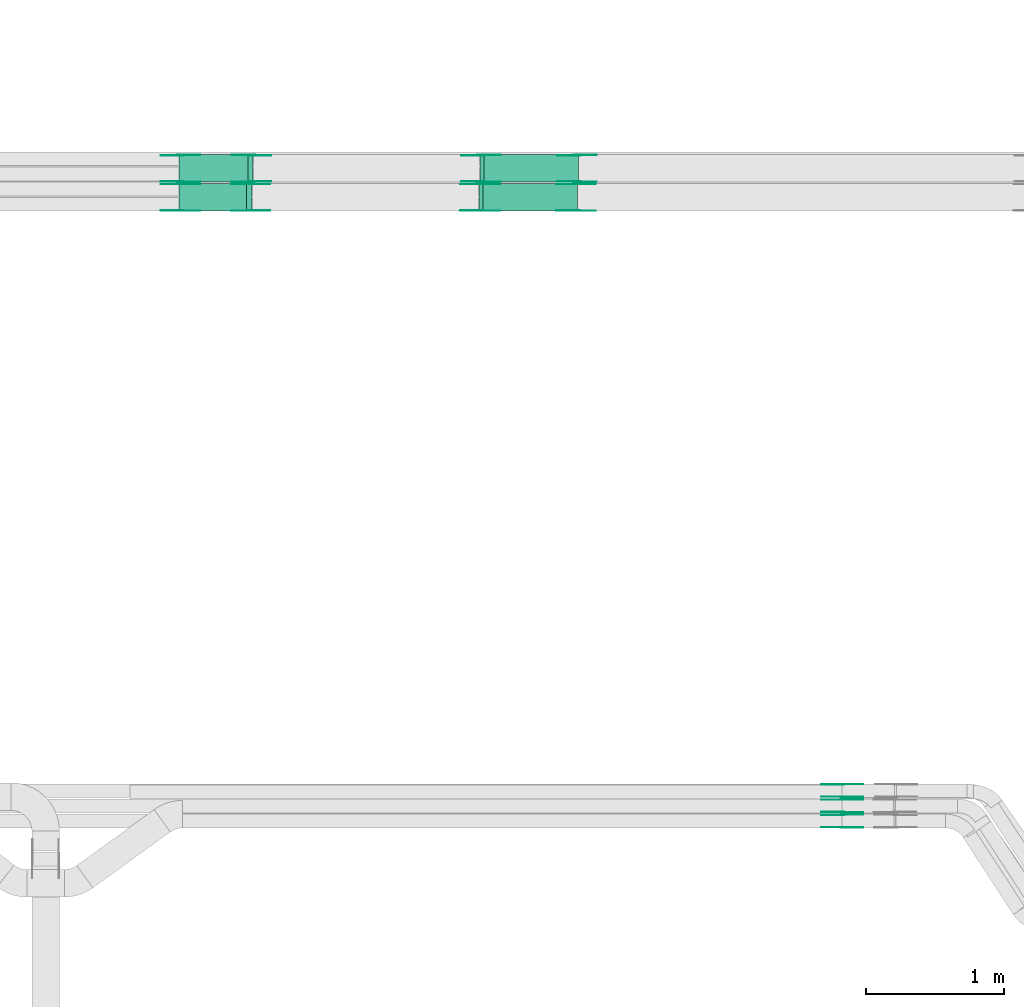
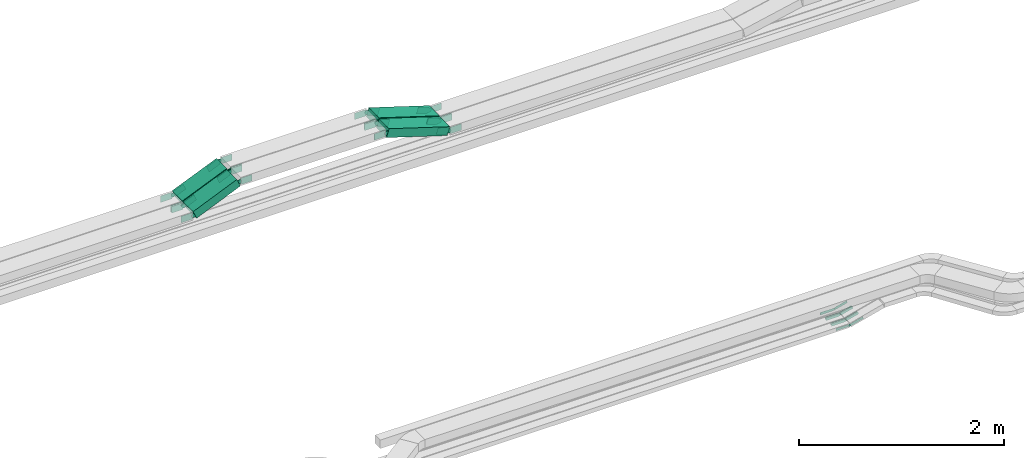
# One storey, part 6 of 25: 44 flow fittings, 4 flow segments.
"""IFC2X3 building model written with IfcOpenShell, lengths in millimetres."""

from ifc_helpers import new_model, entity, si_unit, converted_unit, derived_unit, direction, frame, frame_2d, origin, place, context, subcontext, project, spatial, polyline, circle_curve, parameter, trimmed, segment, composite_curve, rectangle, outline, extrude, source, transform, mapped, material, type_object, type_shapes, element, save


model = new_model("IFC2X3")

# Units and contexts
model_context = context("Model", 3, precision=0.01, world=origin(), true_north=direction((6.12303176911189e-17, 1.0)))
body_context = subcontext(model_context, "Body", "Model", "MODEL_VIEW")
ifc_project = project(units=[si_unit("LENGTHUNIT", "METRE", prefix="MILLI"), si_unit("AREAUNIT", "SQUARE_METRE"), si_unit("VOLUMEUNIT", "CUBIC_METRE"), converted_unit("PLANEANGLEUNIT", "DEGREE", entity("IfcRatioMeasure", 0.0174532925199433), si_unit("PLANEANGLEUNIT", "RADIAN"), dimensions=[0, 0, 0, 0, 0, 0, 0]), si_unit("MASSUNIT", "GRAM", prefix="KILO"), derived_unit("MASSDENSITYUNIT", [(si_unit("MASSUNIT", "GRAM", prefix="KILO"), 1), (si_unit("LENGTHUNIT", "METRE"), -3)]), derived_unit("MOMENTOFINERTIAUNIT", [(si_unit("LENGTHUNIT", "METRE"), 4)]), si_unit("TIMEUNIT", "SECOND"), si_unit("FREQUENCYUNIT", "HERTZ"), si_unit("THERMODYNAMICTEMPERATUREUNIT", "DEGREE_CELSIUS"), derived_unit("THERMALTRANSMITTANCEUNIT", [(si_unit("MASSUNIT", "GRAM", prefix="KILO"), 1), (si_unit("THERMODYNAMICTEMPERATUREUNIT", "KELVIN"), -1), (si_unit("TIMEUNIT", "SECOND"), -3)]), derived_unit("VOLUMETRICFLOWRATEUNIT", [(si_unit("LENGTHUNIT", "METRE"), 3), (si_unit("TIMEUNIT", "SECOND"), -1)]), derived_unit("MASSFLOWRATEUNIT", [(si_unit("MASSUNIT", "GRAM", prefix="KILO"), 1), (si_unit("TIMEUNIT", "SECOND"), -1)]), derived_unit("ROTATIONALFREQUENCYUNIT", [(si_unit("TIMEUNIT", "SECOND"), -1)]), si_unit("ELECTRICCURRENTUNIT", "AMPERE"), si_unit("ELECTRICVOLTAGEUNIT", "VOLT"), si_unit("POWERUNIT", "WATT"), si_unit("FORCEUNIT", "NEWTON", prefix="KILO"), si_unit("ILLUMINANCEUNIT", "LUX"), si_unit("LUMINOUSFLUXUNIT", "LUMEN"), si_unit("LUMINOUSINTENSITYUNIT", "CANDELA"), derived_unit("USERDEFINED", [(si_unit("MASSUNIT", "GRAM", prefix="KILO"), -1), (si_unit("LENGTHUNIT", "METRE"), -2), (si_unit("TIMEUNIT", "SECOND"), 3), (si_unit("LUMINOUSFLUXUNIT", "LUMEN"), 1)]), derived_unit("LINEARVELOCITYUNIT", [(si_unit("LENGTHUNIT", "METRE"), 1), (si_unit("TIMEUNIT", "SECOND"), -1)]), si_unit("PRESSUREUNIT", "PASCAL"), derived_unit("USERDEFINED", [(si_unit("LENGTHUNIT", "METRE"), -2), (si_unit("MASSUNIT", "GRAM", prefix="KILO"), 1), (si_unit("TIMEUNIT", "SECOND"), -2)]), derived_unit("LINEARFORCEUNIT", [(si_unit("MASSUNIT", "GRAM", prefix="KILO"), 1), (si_unit("LENGTHUNIT", "METRE"), 1), (si_unit("TIMEUNIT", "SECOND"), -2), (si_unit("LENGTHUNIT", "METRE"), -1)]), derived_unit("PLANARFORCEUNIT", [(si_unit("MASSUNIT", "GRAM", prefix="KILO"), 1), (si_unit("LENGTHUNIT", "METRE"), 1), (si_unit("TIMEUNIT", "SECOND"), -2), (si_unit("LENGTHUNIT", "METRE"), -2)])], contexts=[model_context])

# Site, building, storey
site_placement = place(None, frame((0.0, -0.00077364408347762, 0.0)))
site = spatial("IfcSite", under=ifc_project, at=site_placement, CompositionType="ELEMENT")
building_placement = place(site_placement, origin())
building = spatial("IfcBuilding", under=site, at=building_placement, CompositionType="ELEMENT")
storey_placement = place(building_placement, frame((0.0, 0.0, 24000.0)))
storey = spatial("IfcBuildingStorey", under=building, at=storey_placement, CompositionType="ELEMENT", Elevation=24000.0)

# Flow segments
cable_carrier_segment_type = type_object("IfcCableCarrierSegmentType", PredefinedType="CABLETRAYSEGMENT")
flow_segment_1_placement = place(storey_placement, frame((23750.3450930717, 14577.8235638228, 2908.57283587758)))
element("IfcFlowSegment", 1, at=flow_segment_1_placement, inside=storey, type_object=cable_carrier_segment_type, context=body_context, shape_type="SweptSolid", body=[
    extrude(rectangle(XDim=99.9999999999979, YDim=200.000000000002, at=frame_2d((-1.99307237380708e-12, 0.0), x_axis=(1.0, 0.0))), frame((19.4417182178709, 100.0, 46.0653838878744), z_axis=(0.921307677757376, 0.0, 0.388834364357512), x_axis=(-0.388834364357512, 0.0, 0.921307677757376)), (0.0, 0.0, 1.0), 541.93656678797),
])
flow_segment_2_placement = place(storey_placement, frame((25932.6643510058, 14577.8235638228, 2905.08448003901)))
element("IfcFlowSegment", 2, at=flow_segment_2_placement, inside=storey, type_object=cable_carrier_segment_type, context=body_context, shape_type="SweptSolid", body=[
    extrude(rectangle(XDim=99.9999999999984, YDim=200.000000000002, at=frame_2d((-4.13180600844498e-12, -2.16715534406831e-12), x_axis=(1.0, 0.0))), frame((14.9913298370202, 100.0, 262.131354076939), z_axis=(0.953993716901251, 0.0, -0.299826596740408), x_axis=(0.299826596740408, 0.0, 0.953993716901251)), (0.0, 0.0, 1.0), 715.185612494235),
])
flow_segment_3_placement = place(storey_placement, frame((23750.2231629393, 14367.8235638228, 2908.77709176211)))
element("IfcFlowSegment", 3, at=flow_segment_3_placement, inside=storey, type_object=cable_carrier_segment_type, context=body_context, shape_type="SweptSolid", body=[
    extrude(rectangle(XDim=99.9999999999976, YDim=200.000000000002, at=frame_2d((1.99307237380708e-12, -2.16715534406831e-12), x_axis=(1.0, 0.0))), frame((19.6676952250639, 100.0, 45.9693567992209), z_axis=(0.919387135984397, 0.0, 0.393353904501287), x_axis=(-0.393353904501287, 0.0, 0.919387135984397)), (0.0, 0.0, 1.0), 535.159561068118),
])
flow_segment_4_placement = place(storey_placement, frame((25925.6009410613, 14367.8235638228, 2905.08448003901)))
element("IfcFlowSegment", 4, at=flow_segment_4_placement, inside=storey, type_object=cable_carrier_segment_type, context=body_context, shape_type="SweptSolid", body=[
    extrude(rectangle(XDim=99.9999999999984, YDim=200.000000000002, at=frame_2d((-4.13180600844498e-12, -2.16715534406831e-12), x_axis=(1.0, 0.0))), frame((14.9913298370202, 100.0, 262.131354076939), z_axis=(0.953993716901251, 0.0, -0.299826596740408), x_axis=(0.299826596740408, 0.0, 0.953993716901251)), (0.0, 0.0, 1.0), 715.185612494268),
])

# Flow fittings
ifc_material = material(Name="G")
cable_carrier_fitting_type_1 = type_object("IfcCableCarrierFittingType", PredefinedType="NOTDEFINED", material=ifc_material)
shared_shape_1 = source(origin(), body_context, "Body", "SweptSolid", [
    extrude(outline(composite_curve([segment(trimmed(circle_curve(frame_2d((-44.5901162790698, 0.0), x_axis=(1.0, 0.0)), 12.5), [parameter(90.0000000000007)], [parameter(270.0)], True, "PARAMETER"), True, "CONTINUOUS"), segment(polyline([(-44.5901162790697, -12.5), (-33.0901162790698, -12.5)]), True, "CONTINUOUS"), segment(polyline([(-33.0901162790698, -12.5), (-31.2296511627907, -14.5)]), True, "CONTINUOUS"), segment(polyline([(-31.2296511627907, -14.5), (108.90988372093, -14.5)]), True, "CONTINUOUS"), segment(polyline([(108.90988372093, -14.5), (108.90988372093, 14.5)]), True, "CONTINUOUS"), segment(polyline([(108.90988372093, 14.5), (-31.2296511627907, 14.5)]), True, "CONTINUOUS"), segment(polyline([(-31.2296511627907, 14.5), (-33.0901162790698, 12.5)]), True, "CONTINUOUS"), segment(polyline([(-33.0901162790698, 12.5), (-44.5901162790699, 12.5)]), True, "CONTINUOUS")], self_intersect=False)), frame((44.5901162790698, 0.0, 0.0), z_axis=(0.0, 0.0, -1.0), x_axis=(1.0, 0.0, 0.0)), (0.0, 0.0, -1.0), 2.0),
])
type_shapes(cable_carrier_fitting_type_1, [shared_shape_1])
for number, where, z_axis, x_axis in (
    (5, (28559.4016711443, 9902.36356392034, 2675.0), (0.0, -1.0, 0.0), (0.967755764973795, 0.0, 0.251890411409375)),
    (6, (28559.4017850089, 10012.3635639189, 2675.00051930279), (0.0, -1.0, 0.0), (0.96722840614087, 0.0, 0.253907877692269)),
    (7, (28559.4017847479, 10122.3635639181, 2675.00051541508), (0.0, -1.0, 0.0), (0.968482292862195, 0.0, 0.249082412892571)),
):
    element("IfcFlowFitting", number, at=place(storey_placement, frame(where, z_axis=z_axis, x_axis=x_axis)), inside=storey, type_object=cable_carrier_fitting_type_1, material=ifc_material, context=body_context, shape_type="MappedRepresentation", body=[
        mapped(shared_shape_1, transform((0.0, 0.0, 0.0), scale=1.0)),
    ])
cable_carrier_fitting_type_2 = type_object("IfcCableCarrierFittingType", PredefinedType="NOTDEFINED", material=ifc_material)
shared_shape_2 = source(origin(), body_context, "Body", "SweptSolid", [
    extrude(outline(composite_curve([segment(trimmed(circle_curve(frame_2d((-44.5901162790697, 0.0), x_axis=(1.0, 0.0)), 12.5), [parameter(90.0000000000007)], [parameter(270.0)], True, "PARAMETER"), True, "CONTINUOUS"), segment(polyline([(-44.5901162790697, -12.5), (-33.0901162790697, -12.5)]), True, "CONTINUOUS"), segment(polyline([(-33.0901162790697, -12.5), (-31.2296511627907, -14.5)]), True, "CONTINUOUS"), segment(polyline([(-31.2296511627907, -14.5), (108.90988372093, -14.5)]), True, "CONTINUOUS"), segment(polyline([(108.90988372093, -14.5), (108.90988372093, 14.5)]), True, "CONTINUOUS"), segment(polyline([(108.90988372093, 14.5), (-31.2296511627907, 14.5)]), True, "CONTINUOUS"), segment(polyline([(-31.2296511627907, 14.5), (-33.0901162790698, 12.5)]), True, "CONTINUOUS"), segment(polyline([(-33.0901162790698, 12.5), (-44.5901162790699, 12.5)]), True, "CONTINUOUS")], self_intersect=False)), frame((44.5901162790697, 0.0, 0.0)), (0.0, 0.0, 1.0), 2.0),
])
type_shapes(cable_carrier_fitting_type_2, [shared_shape_2])
for number, where, z_axis, x_axis in (
    (8, (28559.4016711443, 9993.28356394066, 2675.0), (0.0, 1.0, 0.0), (0.967755764973795, 0.0, 0.251890411409375)),
    (9, (28559.4017850089, 10103.2835639393, 2675.00051930279), (0.0, 1.0, 0.0), (0.96722840614087, 0.0, 0.253907877692269)),
    (10, (28559.4017847479, 10213.2835639385, 2675.00051541508), (0.0, 1.0, 0.0), (0.968482292862195, 0.0, 0.249082412892571)),
):
    element("IfcFlowFitting", number, at=place(storey_placement, frame(where, z_axis=z_axis, x_axis=x_axis)), inside=storey, type_object=cable_carrier_fitting_type_2, material=ifc_material, context=body_context, shape_type="MappedRepresentation", body=[
        mapped(shared_shape_2, transform((0.0, 0.0, 0.0), scale=1.0)),
    ])
cable_carrier_fitting_type_3 = type_object("IfcCableCarrierFittingType", PredefinedType="NOTDEFINED", material=ifc_material)
shared_shape_3 = source(origin(), body_context, "Body", "SweptSolid", [
    extrude(outline(composite_curve([segment(trimmed(circle_curve(frame_2d((-44.5901162790698, 0.0), x_axis=(1.0, 0.0)), 12.5), [parameter(90.0000000000007)], [parameter(270.0)], True, "PARAMETER"), True, "CONTINUOUS"), segment(polyline([(-44.5901162790697, -12.5), (-33.0901162790698, -12.5)]), True, "CONTINUOUS"), segment(polyline([(-33.0901162790698, -12.5), (-31.2296511627907, -14.5)]), True, "CONTINUOUS"), segment(polyline([(-31.2296511627907, -14.5), (108.90988372093, -14.5)]), True, "CONTINUOUS"), segment(polyline([(108.90988372093, -14.5), (108.90988372093, 14.5)]), True, "CONTINUOUS"), segment(polyline([(108.90988372093, 14.5), (-31.2296511627907, 14.5)]), True, "CONTINUOUS"), segment(polyline([(-31.2296511627907, 14.5), (-33.0901162790698, 12.5)]), True, "CONTINUOUS"), segment(polyline([(-33.0901162790698, 12.5), (-44.5901162790699, 12.5)]), True, "CONTINUOUS")], self_intersect=False)), frame((44.5901162790698, 0.0, 0.0), z_axis=(0.0, 0.0, -1.0), x_axis=(1.0, 0.0, 0.0)), (0.0, 0.0, -1.0), 2.0),
])
type_shapes(cable_carrier_fitting_type_3, [shared_shape_3])
for number, where, z_axis, x_axis in (
    (11, (28559.4016711443, 9991.28356394066, 2675.0), (0.0, 1.0, 0.0), (-1.0, 0.0, 0.0)),
    (12, (28559.4017850089, 10101.2835639393, 2675.0005193028), (0.0, 1.0, 0.0), (-1.0, 0.0, -5.74450066331542e-08)),
    (13, (28559.4017847479, 10211.2835639385, 2675.00051541509), (0.0, 1.0, 0.0), (-1.0, 0.0, -5.70149502338435e-08)),
):
    element("IfcFlowFitting", number, at=place(storey_placement, frame(where, z_axis=z_axis, x_axis=x_axis)), inside=storey, type_object=cable_carrier_fitting_type_3, material=ifc_material, context=body_context, shape_type="MappedRepresentation", body=[
        mapped(shared_shape_3, transform((0.0, 0.0, 0.0), scale=1.0)),
    ])
cable_carrier_fitting_type_4 = type_object("IfcCableCarrierFittingType", PredefinedType="NOTDEFINED", material=ifc_material)
shared_shape_4 = source(origin(), body_context, "Body", "SweptSolid", [
    extrude(outline(composite_curve([segment(trimmed(circle_curve(frame_2d((-44.5901162790697, 0.0), x_axis=(1.0, 0.0)), 12.5), [parameter(90.0000000000007)], [parameter(270.0)], True, "PARAMETER"), True, "CONTINUOUS"), segment(polyline([(-44.5901162790697, -12.5), (-33.0901162790697, -12.5)]), True, "CONTINUOUS"), segment(polyline([(-33.0901162790697, -12.5), (-31.2296511627907, -14.5)]), True, "CONTINUOUS"), segment(polyline([(-31.2296511627907, -14.5), (108.90988372093, -14.5)]), True, "CONTINUOUS"), segment(polyline([(108.90988372093, -14.5), (108.90988372093, 14.5)]), True, "CONTINUOUS"), segment(polyline([(108.90988372093, 14.5), (-31.2296511627907, 14.5)]), True, "CONTINUOUS"), segment(polyline([(-31.2296511627907, 14.5), (-33.0901162790698, 12.5)]), True, "CONTINUOUS"), segment(polyline([(-33.0901162790698, 12.5), (-44.5901162790699, 12.5)]), True, "CONTINUOUS")], self_intersect=False)), frame((44.5901162790697, 0.0, 0.0)), (0.0, 0.0, 1.0), 2.0),
])
type_shapes(cable_carrier_fitting_type_4, [shared_shape_4])
for number, where, z_axis, x_axis in (
    (14, (28559.4016711443, 9904.36356392034, 2675.0), (0.0, -1.0, 0.0), (-1.0, 0.0, 0.0)),
    (15, (28559.4017850089, 10014.3635639189, 2675.0005193028), (0.0, -1.0, 0.0), (-1.0, 0.0, -5.74450066331542e-08)),
    (16, (28559.4017847479, 10124.3635639181, 2675.00051541509), (0.0, -1.0, 0.0), (-1.0, 0.0, -5.70149502338435e-08)),
):
    element("IfcFlowFitting", number, at=place(storey_placement, frame(where, z_axis=z_axis, x_axis=x_axis)), inside=storey, type_object=cable_carrier_fitting_type_4, material=ifc_material, context=body_context, shape_type="MappedRepresentation", body=[
        mapped(shared_shape_4, transform((0.0, 0.0, 0.0), scale=1.0)),
    ])
cable_carrier_fitting_type_5 = type_object("IfcCableCarrierFittingType", PredefinedType="NOTDEFINED", material=ifc_material)
shared_shape_5 = source(origin(), body_context, "Body", "SweptSolid", [
    extrude(outline(composite_curve([segment(trimmed(circle_curve(frame_2d((-41.4651162790697, 0.0), x_axis=(1.0, 0.0)), 25.0), [parameter(90.0000000000007)], [parameter(270.0)], True, "PARAMETER"), True, "CONTINUOUS"), segment(polyline([(-41.4651162790697, -25.0), (-29.9651162790697, -25.0)]), True, "CONTINUOUS"), segment(polyline([(-29.9651162790697, -25.0), (-28.1046511627907, -38.5)]), True, "CONTINUOUS"), segment(polyline([(-28.1046511627907, -38.5), (99.5348837209303, -38.5)]), True, "CONTINUOUS"), segment(polyline([(99.5348837209303, -38.5), (99.5348837209303, 38.5)]), True, "CONTINUOUS"), segment(polyline([(99.5348837209303, 38.5), (-28.1046511627907, 38.5)]), True, "CONTINUOUS"), segment(polyline([(-28.1046511627907, 38.5), (-29.9651162790697, 25.0)]), True, "CONTINUOUS"), segment(polyline([(-29.9651162790697, 25.0), (-41.46511627907, 25.0)]), True, "CONTINUOUS")], self_intersect=False)), frame((41.4651162790697, 0.0, 0.0), z_axis=(0.0, 0.0, -1.0), x_axis=(1.0, 0.0, 0.0)), (0.0, 0.0, -1.0), 2.0),
])
type_shapes(cable_carrier_fitting_type_5, [shared_shape_5])
for number, where, z_axis, x_axis in (
    (17, (24280.0669712066, 14582.3635638126, 3170.0), (0.0, -1.0, 0.0), (-0.921307677757369, 0.0, -0.388834364357531)),
    (18, (23758.7969712117, 14582.3635638126, 2950.0), (0.0, -1.0, 0.0), (0.921307677757369, 0.0, 0.388834364357531)),
    (19, (25938.7969712117, 14773.283563833, 3170.0), (0.0, 1.0, 0.0), (0.953993716901241, 0.0, -0.299826596740441)),
    (20, (24273.0035612621, 14372.3635638127, 3170.0), (0.0, -1.0, 0.0), (-0.919387135984396, 0.0, -0.39335390450129)),
    (21, (23758.7969712117, 14372.3635638127, 2950.0), (0.0, -1.0, 0.0), (0.919387135984396, 0.0, 0.39335390450129)),
    (22, (25931.7335612672, 14563.283563833, 3170.0), (0.0, 1.0, 0.0), (0.953993716901241, 0.0, -0.299826596740441)),
    (23, (26638.7969712117, 14582.3635638127, 2950.0), (0.0, -1.0, 0.0), (1.0, 0.0, 0.0)),
    (24, (26631.7335612672, 14372.3635638126, 2950.0), (0.0, -1.0, 0.0), (1.0, 0.0, 0.0)),
):
    element("IfcFlowFitting", number, at=place(storey_placement, frame(where, z_axis=z_axis, x_axis=x_axis)), inside=storey, type_object=cable_carrier_fitting_type_5, material=ifc_material, context=body_context, shape_type="MappedRepresentation", body=[
        mapped(shared_shape_5, transform((0.0, 0.0, 0.0), scale=1.0)),
    ])
cable_carrier_fitting_type_6 = type_object("IfcCableCarrierFittingType", PredefinedType="NOTDEFINED", material=ifc_material)
shared_shape_6 = source(origin(), body_context, "Body", "SweptSolid", [
    extrude(outline(composite_curve([segment(trimmed(circle_curve(frame_2d((-41.4651162790697, 0.0), x_axis=(1.0, 0.0)), 25.0), [parameter(90.0000000000007)], [parameter(270.0)], True, "PARAMETER"), True, "CONTINUOUS"), segment(polyline([(-41.4651162790697, -25.0), (-29.9651162790697, -25.0)]), True, "CONTINUOUS"), segment(polyline([(-29.9651162790697, -25.0), (-28.1046511627907, -38.5)]), True, "CONTINUOUS"), segment(polyline([(-28.1046511627907, -38.5), (99.5348837209303, -38.5)]), True, "CONTINUOUS"), segment(polyline([(99.5348837209303, -38.5), (99.5348837209303, 38.5)]), True, "CONTINUOUS"), segment(polyline([(99.5348837209303, 38.5), (-28.1046511627907, 38.5)]), True, "CONTINUOUS"), segment(polyline([(-28.1046511627907, 38.5), (-29.9651162790697, 25.0)]), True, "CONTINUOUS"), segment(polyline([(-29.9651162790697, 25.0), (-41.46511627907, 25.0)]), True, "CONTINUOUS")], self_intersect=False)), frame((41.4651162790697, 0.0, 0.0)), (0.0, 0.0, 1.0), 2.0),
])
type_shapes(cable_carrier_fitting_type_6, [shared_shape_6])
for number, where, z_axis, x_axis in (
    (25, (24280.0669712066, 14773.283563833, 3170.0), (0.0, 1.0, 0.0), (-0.921307677757369, 0.0, -0.388834364357531)),
    (26, (23758.7969712117, 14773.283563833, 2950.0), (0.0, 1.0, 0.0), (0.921307677757369, 0.0, 0.388834364357531)),
    (27, (25938.7969712117, 14582.3635638127, 3170.0), (0.0, -1.0, 0.0), (0.953993716901241, 0.0, -0.299826596740441)),
    (28, (24273.0035612621, 14563.283563833, 3170.0), (0.0, 1.0, 0.0), (-0.919387135984396, 0.0, -0.39335390450129)),
    (29, (23758.7969712117, 14563.283563833, 2950.0), (0.0, 1.0, 0.0), (0.919387135984396, 0.0, 0.39335390450129)),
    (30, (25931.7335612672, 14372.3635638126, 3170.0), (0.0, -1.0, 0.0), (0.953993716901241, 0.0, -0.299826596740441)),
    (31, (26638.7969712117, 14773.283563833, 2950.0), (0.0, 1.0, 0.0), (1.0, 0.0, 0.0)),
    (32, (26631.7335612672, 14563.283563833, 2950.0), (0.0, 1.0, 0.0), (1.0, 0.0, 0.0)),
):
    element("IfcFlowFitting", number, at=place(storey_placement, frame(where, z_axis=z_axis, x_axis=x_axis)), inside=storey, type_object=cable_carrier_fitting_type_6, material=ifc_material, context=body_context, shape_type="MappedRepresentation", body=[
        mapped(shared_shape_6, transform((0.0, 0.0, 0.0), scale=1.0)),
    ])
cable_carrier_fitting_type_7 = type_object("IfcCableCarrierFittingType", PredefinedType="NOTDEFINED", material=ifc_material)
shared_shape_7 = source(origin(), body_context, "Body", "SweptSolid", [
    extrude(outline(composite_curve([segment(trimmed(circle_curve(frame_2d((-41.4651162790697, 0.0), x_axis=(1.0, 0.0)), 25.0), [parameter(90.0000000000007)], [parameter(270.0)], True, "PARAMETER"), True, "CONTINUOUS"), segment(polyline([(-41.4651162790697, -25.0), (-29.9651162790697, -25.0)]), True, "CONTINUOUS"), segment(polyline([(-29.9651162790697, -25.0), (-28.1046511627907, -38.5)]), True, "CONTINUOUS"), segment(polyline([(-28.1046511627907, -38.5), (99.5348837209303, -38.5)]), True, "CONTINUOUS"), segment(polyline([(99.5348837209303, -38.5), (99.5348837209303, 38.5)]), True, "CONTINUOUS"), segment(polyline([(99.5348837209303, 38.5), (-28.1046511627907, 38.5)]), True, "CONTINUOUS"), segment(polyline([(-28.1046511627907, 38.5), (-29.9651162790697, 25.0)]), True, "CONTINUOUS"), segment(polyline([(-29.9651162790697, 25.0), (-41.46511627907, 25.0)]), True, "CONTINUOUS")], self_intersect=False)), frame((41.4651162790697, 0.0, 0.0), z_axis=(0.0, 0.0, -1.0), x_axis=(1.0, 0.0, 0.0)), (0.0, 0.0, -1.0), 2.0),
])
type_shapes(cable_carrier_fitting_type_7, [shared_shape_7])
for number, where, z_axis, x_axis in (
    (33, (24280.0669712066, 14771.283563833, 3170.0), (0.0, 1.0, 0.0), (1.0, 0.0, 0.0)),
    (34, (23758.7969712117, 14771.283563833, 2950.0), (0.0, 1.0, 0.0), (-1.0, 0.0, 0.0)),
    (35, (25938.7969712117, 14584.3635638126, 3170.0), (0.0, -1.0, 0.0), (-1.0, 0.0, 0.0)),
    (36, (24273.0035612621, 14561.283563833, 3170.0), (0.0, 1.0, 0.0), (1.0, 0.0, 0.0)),
    (37, (23758.7969712117, 14561.283563833, 2950.0), (0.0, 1.0, 0.0), (-1.0, 0.0, 0.0)),
    (38, (25931.7335612672, 14374.3635638126, 3170.0), (0.0, -1.0, 0.0), (-1.0, 0.0, 0.0)),
    (39, (26638.7969712117, 14771.283563833, 2950.0), (0.0, 1.0, 0.0), (-0.953993716901243, 0.0, 0.299826596740433)),
    (40, (26631.7335612672, 14561.283563833, 2950.0), (0.0, 1.0, 0.0), (-0.95399371690125, 0.0, 0.299826596740412)),
):
    element("IfcFlowFitting", number, at=place(storey_placement, frame(where, z_axis=z_axis, x_axis=x_axis)), inside=storey, type_object=cable_carrier_fitting_type_7, material=ifc_material, context=body_context, shape_type="MappedRepresentation", body=[
        mapped(shared_shape_7, transform((0.0, 0.0, 0.0), scale=1.0)),
    ])
cable_carrier_fitting_type_8 = type_object("IfcCableCarrierFittingType", PredefinedType="NOTDEFINED", material=ifc_material)
shared_shape_8 = source(origin(), body_context, "Body", "SweptSolid", [
    extrude(outline(composite_curve([segment(trimmed(circle_curve(frame_2d((-41.4651162790697, 0.0), x_axis=(1.0, 0.0)), 25.0), [parameter(90.0000000000007)], [parameter(270.0)], True, "PARAMETER"), True, "CONTINUOUS"), segment(polyline([(-41.4651162790697, -25.0), (-29.9651162790697, -25.0)]), True, "CONTINUOUS"), segment(polyline([(-29.9651162790697, -25.0), (-28.1046511627907, -38.5)]), True, "CONTINUOUS"), segment(polyline([(-28.1046511627907, -38.5), (99.5348837209303, -38.5)]), True, "CONTINUOUS"), segment(polyline([(99.5348837209303, -38.5), (99.5348837209303, 38.5)]), True, "CONTINUOUS"), segment(polyline([(99.5348837209303, 38.5), (-28.1046511627907, 38.5)]), True, "CONTINUOUS"), segment(polyline([(-28.1046511627907, 38.5), (-29.9651162790697, 25.0)]), True, "CONTINUOUS"), segment(polyline([(-29.9651162790697, 25.0), (-41.46511627907, 25.0)]), True, "CONTINUOUS")], self_intersect=False)), frame((41.4651162790697, 0.0, 0.0)), (0.0, 0.0, 1.0), 2.0),
])
type_shapes(cable_carrier_fitting_type_8, [shared_shape_8])
for number, where, z_axis, x_axis in (
    (41, (24280.0669712066, 14584.3635638126, 3170.0), (0.0, -1.0, 0.0), (1.0, 0.0, 0.0)),
    (42, (23758.7969712117, 14584.3635638126, 2950.0), (0.0, -1.0, 0.0), (-1.0, 0.0, 0.0)),
    (43, (25938.7969712117, 14771.283563833, 3170.0), (0.0, 1.0, 0.0), (-1.0, 0.0, 0.0)),
    (44, (24273.0035612621, 14374.3635638127, 3170.0), (0.0, -1.0, 0.0), (1.0, 0.0, 0.0)),
    (45, (23758.7969712117, 14374.3635638127, 2950.0), (0.0, -1.0, 0.0), (-1.0, 0.0, 0.0)),
    (46, (25931.7335612672, 14561.283563833, 3170.0), (0.0, 1.0, 0.0), (-1.0, 0.0, 0.0)),
    (47, (26638.7969712117, 14584.3635638127, 2950.0), (0.0, -1.0, 0.0), (-0.953993716901243, 0.0, 0.299826596740433)),
    (48, (26631.7335612672, 14374.3635638127, 2950.0), (0.0, -1.0, 0.0), (-0.95399371690125, 0.0, 0.299826596740412)),
):
    element("IfcFlowFitting", number, at=place(storey_placement, frame(where, z_axis=z_axis, x_axis=x_axis)), inside=storey, type_object=cable_carrier_fitting_type_8, material=ifc_material, context=body_context, shape_type="MappedRepresentation", body=[
        mapped(shared_shape_8, transform((0.0, 0.0, 0.0), scale=1.0)),
    ])

save(model, "model.ifc")
